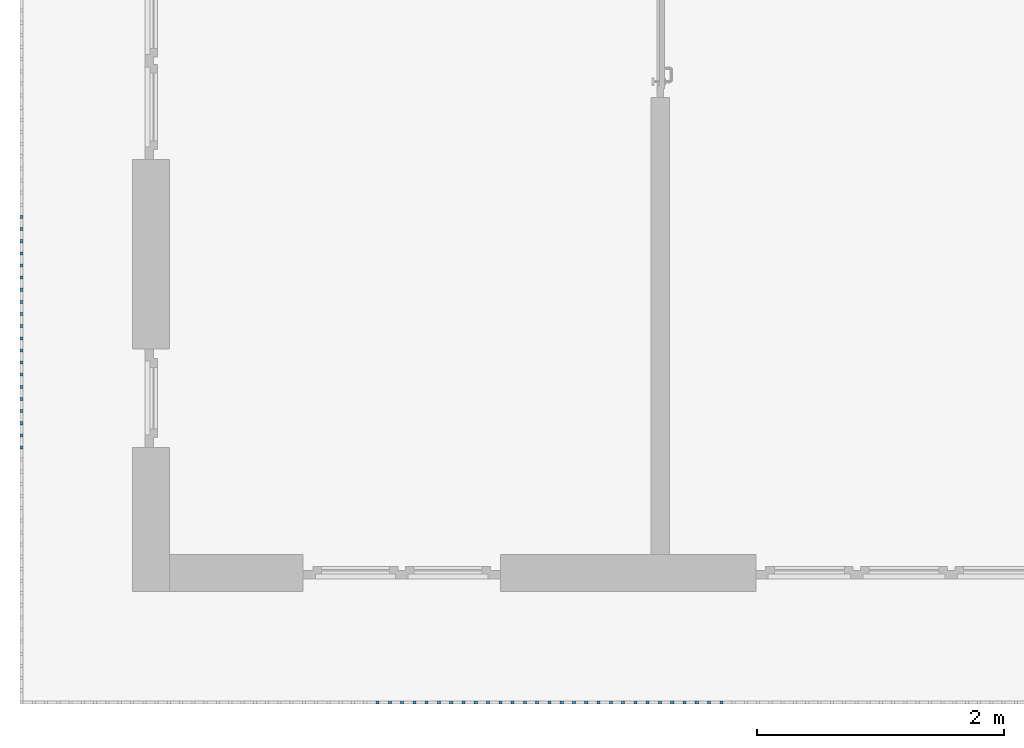
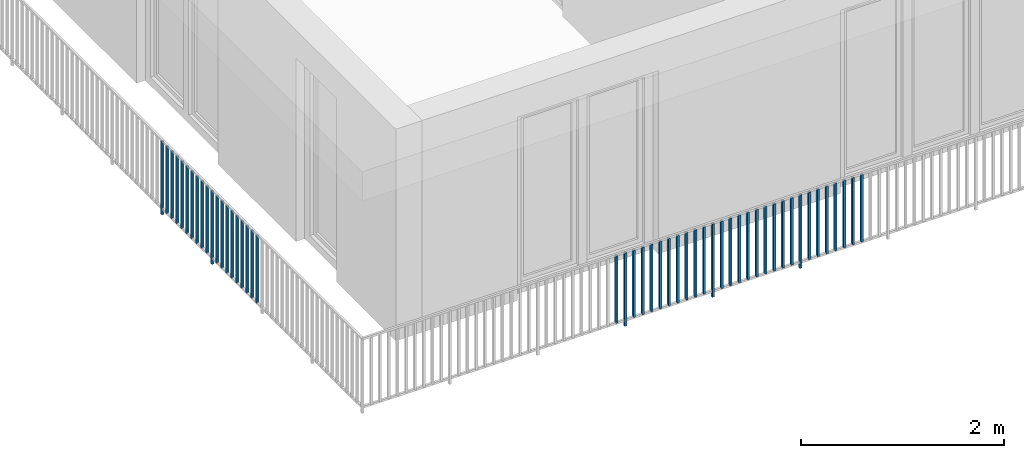
# One storey, part 32 of 54: 49 building element parts, 1 element without a shape of its own.
"""IFC4 building model written with IfcOpenShell, lengths in metres."""

from ifc_helpers import new_model, entity, si_unit, converted_unit, derived_unit, direction, frame, origin_with_axes, place, context, subcontext, project, spatial, polygons, material, type_object, element, aggregate, save


model = new_model("IFC4")

# Units and contexts
model_context = context("Model", 3, precision=1e-05, world=origin_with_axes(), true_north=direction((0.0, 1.0)))
body_context = subcontext(model_context, "Body", "Model", "MODEL_VIEW")
ifc_project = project(units=[si_unit("LENGTHUNIT", "METRE"), si_unit("AREAUNIT", "SQUARE_METRE"), si_unit("VOLUMEUNIT", "CUBIC_METRE"), converted_unit("PLANEANGLEUNIT", "DEGREE", entity("IfcPlaneAngleMeasure", 0.0174532925199), si_unit("PLANEANGLEUNIT", "RADIAN"), dimensions=[0, 0, 0, 0, 0, 0, 0]), converted_unit("TIMEUNIT", "Year", entity("IfcTimeMeasure", 31556926.0), si_unit("TIMEUNIT", "SECOND"), dimensions=[0, 0, 1, 0, 0, 0, 0]), si_unit("MASSUNIT", "GRAM", prefix="KILO"), si_unit("THERMODYNAMICTEMPERATUREUNIT", "DEGREE_CELSIUS"), si_unit("LUMINOUSINTENSITYUNIT", "LUMEN"), si_unit("ENERGYUNIT", "JOULE", prefix="MEGA"), derived_unit("THERMALCONDUCTANCEUNIT", [(si_unit("POWERUNIT", "WATT"), 1), (si_unit("LENGTHUNIT", "METRE"), -1), (si_unit("THERMODYNAMICTEMPERATUREUNIT", "KELVIN"), -1)]), derived_unit("SPECIFICHEATCAPACITYUNIT", [(si_unit("ENERGYUNIT", "JOULE"), 1), (si_unit("MASSUNIT", "GRAM", prefix="KILO"), -1), (si_unit("THERMODYNAMICTEMPERATUREUNIT", "KELVIN"), -1)]), derived_unit("MASSDENSITYUNIT", [(si_unit("MASSUNIT", "GRAM", prefix="KILO"), 1), (si_unit("VOLUMEUNIT", "CUBIC_METRE"), -1)])], contexts=[model_context])

# Site, building, storey, space
site_placement = place(None, origin_with_axes())
site = spatial("IfcSite", under=ifc_project, at=site_placement, CompositionType="ELEMENT")
building_placement = place(site_placement, origin_with_axes())
building = spatial("IfcBuilding", under=site, at=building_placement, CompositionType="ELEMENT")
storey_placement = place(building_placement, frame((0.0, 0.0, 6.29), z_axis=(0.0, 0.0, 1.0), x_axis=(1.0, 0.0, 0.0)))
storey = spatial("IfcBuildingStorey", under=building, at=storey_placement, Name="2. Geschoss", CompositionType="ELEMENT", Elevation=6.29)
space_placement = place(storey_placement, frame((10.2378006196, 9.82118769833, 0.0), z_axis=(0.0, 0.0, 1.0), x_axis=(-1.0, 0.0, 0.0)))
space = spatial("IfcSpace", under=storey, at=space_placement, CompositionType="ELEMENT", PredefinedType="EXTERNAL")

# Railing, building element parts
railing_type = type_object("IfcRailingType", PredefinedType="NOTDEFINED")
railing_placement = place(space_placement, frame((0.0, -7.06315681498e-08, 0.0), z_axis=(0.0, 0.0, 1.0), x_axis=(-1.0, 0.0, 0.0)))
railing = element("IfcRailing", 1, at=railing_placement, inside=space, type_object=railing_type, PredefinedType="NOTDEFINED")
ifc_material = material()
building_element_part_1_placement = place(railing_placement, origin_with_axes())
building_element_part_1 = element("IfcBuildingElementPart", 2, at=building_element_part_1_placement, material=ifc_material, PredefinedType="NOTDEFINED", context=body_context, shape_type="Tessellation", body=[
    polygons([(-22.8925, -16.7291666667, 0.0), (-22.8675, -16.7291666667, 0.0), (-22.8675, -16.7291666667, 0.88), (-22.8925, -16.7291666667, 0.88), (-22.8925, -16.7041666667, 0.0), (-22.8675, -16.7041666667, 0.0), (-22.8675, -16.7041666667, 0.88), (-22.8925, -16.7041666667, 0.88)], [[[1, 2, 3, 4]], [[1, 5, 6, 2]], [[2, 6, 7, 3]], [[4, 3, 7, 8]], [[5, 1, 4, 8]], [[6, 5, 8, 7]]], closed=True),
])
building_element_part_2_placement = place(railing_placement, origin_with_axes())
building_element_part_2 = element("IfcBuildingElementPart", 3, at=building_element_part_2_placement, material=ifc_material, PredefinedType="NOTDEFINED", context=body_context, shape_type="Tessellation", body=[
    polygons([(-22.8925, -16.8275, 0.07), (-22.8675, -16.8275, 0.07), (-22.8675, -16.8275, 0.8775), (-22.8925, -16.8275, 0.8775), (-22.8925, -16.8025, 0.07), (-22.8675, -16.8025, 0.07), (-22.8675, -16.8025, 0.8775), (-22.8925, -16.8025, 0.8775)], [[[1, 2, 3, 4]], [[1, 5, 6, 2]], [[2, 6, 7, 3]], [[4, 3, 7, 8]], [[5, 1, 4, 8]], [[6, 5, 8, 7]]], closed=True),
])
building_element_part_3_placement = place(railing_placement, origin_with_axes())
building_element_part_3 = element("IfcBuildingElementPart", 4, at=building_element_part_3_placement, material=ifc_material, PredefinedType="NOTDEFINED", context=body_context, shape_type="Tessellation", body=[
    polygons([(-22.8925, -16.9258333333, 0.07), (-22.8675, -16.9258333333, 0.07), (-22.8675, -16.9258333333, 0.8775), (-22.8925, -16.9258333333, 0.8775), (-22.8925, -16.9008333333, 0.07), (-22.8675, -16.9008333333, 0.07), (-22.8675, -16.9008333333, 0.8775), (-22.8925, -16.9008333333, 0.8775)], [[[1, 2, 3, 4]], [[1, 5, 6, 2]], [[2, 6, 7, 3]], [[4, 3, 7, 8]], [[5, 1, 4, 8]], [[6, 5, 8, 7]]], closed=True),
])
building_element_part_4_placement = place(railing_placement, origin_with_axes())
building_element_part_4 = element("IfcBuildingElementPart", 5, at=building_element_part_4_placement, material=ifc_material, PredefinedType="NOTDEFINED", context=body_context, shape_type="Tessellation", body=[
    polygons([(-22.8925, -17.0241666667, 0.07), (-22.8675, -17.0241666667, 0.07), (-22.8675, -17.0241666667, 0.8775), (-22.8925, -17.0241666667, 0.8775), (-22.8925, -16.9991666667, 0.07), (-22.8675, -16.9991666667, 0.07), (-22.8675, -16.9991666667, 0.8775), (-22.8925, -16.9991666667, 0.8775)], [[[1, 2, 3, 4]], [[1, 5, 6, 2]], [[2, 6, 7, 3]], [[4, 3, 7, 8]], [[5, 1, 4, 8]], [[6, 5, 8, 7]]], closed=True),
])
building_element_part_5_placement = place(railing_placement, origin_with_axes())
building_element_part_5 = element("IfcBuildingElementPart", 6, at=building_element_part_5_placement, material=ifc_material, PredefinedType="NOTDEFINED", context=body_context, shape_type="Tessellation", body=[
    polygons([(-22.8925, -17.1225, 0.07), (-22.8675, -17.1225, 0.07), (-22.8675, -17.1225, 0.8775), (-22.8925, -17.1225, 0.8775), (-22.8925, -17.0975, 0.07), (-22.8675, -17.0975, 0.07), (-22.8675, -17.0975, 0.8775), (-22.8925, -17.0975, 0.8775)], [[[1, 2, 3, 4]], [[1, 5, 6, 2]], [[2, 6, 7, 3]], [[4, 3, 7, 8]], [[5, 1, 4, 8]], [[6, 5, 8, 7]]], closed=True),
])
building_element_part_6_placement = place(railing_placement, origin_with_axes())
building_element_part_6 = element("IfcBuildingElementPart", 7, at=building_element_part_6_placement, material=ifc_material, PredefinedType="NOTDEFINED", context=body_context, shape_type="Tessellation", body=[
    polygons([(-22.8925, -17.2208333333, 0.07), (-22.8675, -17.2208333333, 0.07), (-22.8675, -17.2208333333, 0.8775), (-22.8925, -17.2208333333, 0.8775), (-22.8925, -17.1958333333, 0.07), (-22.8675, -17.1958333333, 0.07), (-22.8675, -17.1958333333, 0.8775), (-22.8925, -17.1958333333, 0.8775)], [[[1, 2, 3, 4]], [[1, 5, 6, 2]], [[2, 6, 7, 3]], [[4, 3, 7, 8]], [[5, 1, 4, 8]], [[6, 5, 8, 7]]], closed=True),
])
building_element_part_7_placement = place(railing_placement, origin_with_axes())
building_element_part_7 = element("IfcBuildingElementPart", 8, at=building_element_part_7_placement, material=ifc_material, PredefinedType="NOTDEFINED", context=body_context, shape_type="Tessellation", body=[
    polygons([(-22.8925, -17.3191666667, 0.07), (-22.8675, -17.3191666667, 0.07), (-22.8675, -17.3191666667, 0.8775), (-22.8925, -17.3191666667, 0.8775), (-22.8925, -17.2941666667, 0.07), (-22.8675, -17.2941666667, 0.07), (-22.8675, -17.2941666667, 0.8775), (-22.8925, -17.2941666667, 0.8775)], [[[1, 2, 3, 4]], [[1, 5, 6, 2]], [[2, 6, 7, 3]], [[4, 3, 7, 8]], [[5, 1, 4, 8]], [[6, 5, 8, 7]]], closed=True),
])
building_element_part_8_placement = place(railing_placement, origin_with_axes())
building_element_part_8 = element("IfcBuildingElementPart", 9, at=building_element_part_8_placement, material=ifc_material, PredefinedType="NOTDEFINED", context=body_context, shape_type="Tessellation", body=[
    polygons([(-22.8925, -17.4175, 0.07), (-22.8675, -17.4175, 0.07), (-22.8675, -17.4175, 0.8775), (-22.8925, -17.4175, 0.8775), (-22.8925, -17.3925, 0.07), (-22.8675, -17.3925, 0.07), (-22.8675, -17.3925, 0.8775), (-22.8925, -17.3925, 0.8775)], [[[1, 2, 3, 4]], [[1, 5, 6, 2]], [[2, 6, 7, 3]], [[4, 3, 7, 8]], [[5, 1, 4, 8]], [[6, 5, 8, 7]]], closed=True),
])
building_element_part_9_placement = place(railing_placement, origin_with_axes())
building_element_part_9 = element("IfcBuildingElementPart", 10, at=building_element_part_9_placement, material=ifc_material, PredefinedType="NOTDEFINED", context=body_context, shape_type="Tessellation", body=[
    polygons([(-22.8925, -17.5158333333, 0.07), (-22.8675, -17.5158333333, 0.07), (-22.8675, -17.5158333333, 0.8775), (-22.8925, -17.5158333333, 0.8775), (-22.8925, -17.4908333333, 0.07), (-22.8675, -17.4908333333, 0.07), (-22.8675, -17.4908333333, 0.8775), (-22.8925, -17.4908333333, 0.8775)], [[[1, 2, 3, 4]], [[1, 5, 6, 2]], [[2, 6, 7, 3]], [[4, 3, 7, 8]], [[5, 1, 4, 8]], [[6, 5, 8, 7]]], closed=True),
])
building_element_part_10_placement = place(railing_placement, origin_with_axes())
building_element_part_10 = element("IfcBuildingElementPart", 11, at=building_element_part_10_placement, material=ifc_material, PredefinedType="NOTDEFINED", context=body_context, shape_type="Tessellation", body=[
    polygons([(-22.8925, -17.6141666667, 0.07), (-22.8675, -17.6141666667, 0.07), (-22.8675, -17.6141666667, 0.8775), (-22.8925, -17.6141666667, 0.8775), (-22.8925, -17.5891666667, 0.07), (-22.8675, -17.5891666667, 0.07), (-22.8675, -17.5891666667, 0.8775), (-22.8925, -17.5891666667, 0.8775)], [[[1, 2, 3, 4]], [[1, 5, 6, 2]], [[2, 6, 7, 3]], [[4, 3, 7, 8]], [[5, 1, 4, 8]], [[6, 5, 8, 7]]], closed=True),
])
building_element_part_11_placement = place(railing_placement, origin_with_axes())
building_element_part_11 = element("IfcBuildingElementPart", 12, at=building_element_part_11_placement, material=ifc_material, PredefinedType="NOTDEFINED", context=body_context, shape_type="Tessellation", body=[
    polygons([(-22.8925, -17.7125, 0.0), (-22.8675, -17.7125, 0.0), (-22.8675, -17.7125, 0.88), (-22.8925, -17.7125, 0.88), (-22.8925, -17.6875, 0.0), (-22.8675, -17.6875, 0.0), (-22.8675, -17.6875, 0.88), (-22.8925, -17.6875, 0.88)], [[[1, 2, 3, 4]], [[1, 5, 6, 2]], [[2, 6, 7, 3]], [[4, 3, 7, 8]], [[5, 1, 4, 8]], [[6, 5, 8, 7]]], closed=True),
])
building_element_part_12_placement = place(railing_placement, origin_with_axes())
building_element_part_12 = element("IfcBuildingElementPart", 13, at=building_element_part_12_placement, material=ifc_material, PredefinedType="NOTDEFINED", context=body_context, shape_type="Tessellation", body=[
    polygons([(-22.8925, -17.8108333333, 0.07), (-22.8675, -17.8108333333, 0.07), (-22.8675, -17.8108333333, 0.8775), (-22.8925, -17.8108333333, 0.8775), (-22.8925, -17.7858333333, 0.07), (-22.8675, -17.7858333333, 0.07), (-22.8675, -17.7858333333, 0.8775), (-22.8925, -17.7858333333, 0.8775)], [[[1, 2, 3, 4]], [[1, 5, 6, 2]], [[2, 6, 7, 3]], [[4, 3, 7, 8]], [[5, 1, 4, 8]], [[6, 5, 8, 7]]], closed=True),
])
building_element_part_13_placement = place(railing_placement, origin_with_axes())
building_element_part_13 = element("IfcBuildingElementPart", 14, at=building_element_part_13_placement, material=ifc_material, PredefinedType="NOTDEFINED", context=body_context, shape_type="Tessellation", body=[
    polygons([(-22.8925, -17.9091666667, 0.07), (-22.8675, -17.9091666667, 0.07), (-22.8675, -17.9091666667, 0.8775), (-22.8925, -17.9091666667, 0.8775), (-22.8925, -17.8841666667, 0.07), (-22.8675, -17.8841666667, 0.07), (-22.8675, -17.8841666667, 0.8775), (-22.8925, -17.8841666667, 0.8775)], [[[1, 2, 3, 4]], [[1, 5, 6, 2]], [[2, 6, 7, 3]], [[4, 3, 7, 8]], [[5, 1, 4, 8]], [[6, 5, 8, 7]]], closed=True),
])
building_element_part_14_placement = place(railing_placement, origin_with_axes())
building_element_part_14 = element("IfcBuildingElementPart", 15, at=building_element_part_14_placement, material=ifc_material, PredefinedType="NOTDEFINED", context=body_context, shape_type="Tessellation", body=[
    polygons([(-22.8925, -18.0075, 0.07), (-22.8675, -18.0075, 0.07), (-22.8675, -18.0075, 0.8775), (-22.8925, -18.0075, 0.8775), (-22.8925, -17.9825, 0.07), (-22.8675, -17.9825, 0.07), (-22.8675, -17.9825, 0.8775), (-22.8925, -17.9825, 0.8775)], [[[1, 2, 3, 4]], [[1, 5, 6, 2]], [[2, 6, 7, 3]], [[4, 3, 7, 8]], [[5, 1, 4, 8]], [[6, 5, 8, 7]]], closed=True),
])
building_element_part_15_placement = place(railing_placement, origin_with_axes())
building_element_part_15 = element("IfcBuildingElementPart", 16, at=building_element_part_15_placement, material=ifc_material, PredefinedType="NOTDEFINED", context=body_context, shape_type="Tessellation", body=[
    polygons([(-22.8925, -18.1058333333, 0.07), (-22.8675, -18.1058333333, 0.07), (-22.8675, -18.1058333333, 0.8775), (-22.8925, -18.1058333333, 0.8775), (-22.8925, -18.0808333333, 0.07), (-22.8675, -18.0808333333, 0.07), (-22.8675, -18.0808333333, 0.8775), (-22.8925, -18.0808333333, 0.8775)], [[[1, 2, 3, 4]], [[1, 5, 6, 2]], [[2, 6, 7, 3]], [[4, 3, 7, 8]], [[5, 1, 4, 8]], [[6, 5, 8, 7]]], closed=True),
])
building_element_part_16_placement = place(railing_placement, origin_with_axes())
building_element_part_16 = element("IfcBuildingElementPart", 17, at=building_element_part_16_placement, material=ifc_material, PredefinedType="NOTDEFINED", context=body_context, shape_type="Tessellation", body=[
    polygons([(-22.8925, -18.2041666667, 0.07), (-22.8675, -18.2041666667, 0.07), (-22.8675, -18.2041666667, 0.8775), (-22.8925, -18.2041666667, 0.8775), (-22.8925, -18.1791666667, 0.07), (-22.8675, -18.1791666667, 0.07), (-22.8675, -18.1791666667, 0.8775), (-22.8925, -18.1791666667, 0.8775)], [[[1, 2, 3, 4]], [[1, 5, 6, 2]], [[2, 6, 7, 3]], [[4, 3, 7, 8]], [[5, 1, 4, 8]], [[6, 5, 8, 7]]], closed=True),
])
building_element_part_17_placement = place(railing_placement, origin_with_axes())
building_element_part_17 = element("IfcBuildingElementPart", 18, at=building_element_part_17_placement, material=ifc_material, PredefinedType="NOTDEFINED", context=body_context, shape_type="Tessellation", body=[
    polygons([(-22.8925, -18.3025, 0.07), (-22.8675, -18.3025, 0.07), (-22.8675, -18.3025, 0.8775), (-22.8925, -18.3025, 0.8775), (-22.8925, -18.2775, 0.07), (-22.8675, -18.2775, 0.07), (-22.8675, -18.2775, 0.8775), (-22.8925, -18.2775, 0.8775)], [[[1, 2, 3, 4]], [[1, 5, 6, 2]], [[2, 6, 7, 3]], [[4, 3, 7, 8]], [[5, 1, 4, 8]], [[6, 5, 8, 7]]], closed=True),
])
building_element_part_18_placement = place(railing_placement, origin_with_axes())
building_element_part_18 = element("IfcBuildingElementPart", 19, at=building_element_part_18_placement, material=ifc_material, PredefinedType="NOTDEFINED", context=body_context, shape_type="Tessellation", body=[
    polygons([(-22.8925, -18.4008333333, 0.07), (-22.8675, -18.4008333333, 0.07), (-22.8675, -18.4008333333, 0.8775), (-22.8925, -18.4008333333, 0.8775), (-22.8925, -18.3758333333, 0.07), (-22.8675, -18.3758333333, 0.07), (-22.8675, -18.3758333333, 0.8775), (-22.8925, -18.3758333333, 0.8775)], [[[1, 2, 3, 4]], [[1, 5, 6, 2]], [[2, 6, 7, 3]], [[4, 3, 7, 8]], [[5, 1, 4, 8]], [[6, 5, 8, 7]]], closed=True),
])
building_element_part_19_placement = place(railing_placement, origin_with_axes())
building_element_part_19 = element("IfcBuildingElementPart", 20, at=building_element_part_19_placement, material=ifc_material, PredefinedType="NOTDEFINED", context=body_context, shape_type="Tessellation", body=[
    polygons([(-22.8925, -18.4991666667, 0.07), (-22.8675, -18.4991666667, 0.07), (-22.8675, -18.4991666667, 0.8775), (-22.8925, -18.4991666667, 0.8775), (-22.8925, -18.4741666667, 0.07), (-22.8675, -18.4741666667, 0.07), (-22.8675, -18.4741666667, 0.8775), (-22.8925, -18.4741666667, 0.8775)], [[[1, 2, 3, 4]], [[1, 5, 6, 2]], [[2, 6, 7, 3]], [[4, 3, 7, 8]], [[5, 1, 4, 8]], [[6, 5, 8, 7]]], closed=True),
])
building_element_part_20_placement = place(railing_placement, origin_with_axes())
building_element_part_20 = element("IfcBuildingElementPart", 21, at=building_element_part_20_placement, material=ifc_material, PredefinedType="NOTDEFINED", context=body_context, shape_type="Tessellation", body=[
    polygons([(-22.8925, -18.5975, 0.07), (-22.8675, -18.5975, 0.07), (-22.8675, -18.5975, 0.8775), (-22.8925, -18.5975, 0.8775), (-22.8925, -18.5725, 0.07), (-22.8675, -18.5725, 0.07), (-22.8675, -18.5725, 0.8775), (-22.8925, -18.5725, 0.8775)], [[[1, 2, 3, 4]], [[1, 5, 6, 2]], [[2, 6, 7, 3]], [[4, 3, 7, 8]], [[5, 1, 4, 8]], [[6, 5, 8, 7]]], closed=True),
])
building_element_part_21_placement = place(railing_placement, origin_with_axes())
building_element_part_21 = element("IfcBuildingElementPart", 22, at=building_element_part_21_placement, material=ifc_material, PredefinedType="NOTDEFINED", context=body_context, shape_type="Tessellation", body=[
    polygons([(-19.9826304348, -20.6625, 0.07), (-19.9826304348, -20.6375, 0.07), (-19.9826304348, -20.6375, 0.8775), (-19.9826304348, -20.6625, 0.8775), (-20.0076304348, -20.6625, 0.07), (-20.0076304348, -20.6375, 0.07), (-20.0076304348, -20.6375, 0.8775), (-20.0076304348, -20.6625, 0.8775)], [[[1, 2, 3, 4]], [[1, 5, 6, 2]], [[2, 6, 7, 3]], [[4, 3, 7, 8]], [[5, 1, 4, 8]], [[6, 5, 8, 7]]], closed=True),
])
building_element_part_22_placement = place(railing_placement, origin_with_axes())
building_element_part_22 = element("IfcBuildingElementPart", 23, at=building_element_part_22_placement, material=ifc_material, PredefinedType="NOTDEFINED", context=body_context, shape_type="Tessellation", body=[
    polygons([(-19.8831521739, -20.6625, 0.0), (-19.8831521739, -20.6375, 0.0), (-19.8831521739, -20.6375, 0.88), (-19.8831521739, -20.6625, 0.88), (-19.9081521739, -20.6625, 0.0), (-19.9081521739, -20.6375, 0.0), (-19.9081521739, -20.6375, 0.88), (-19.9081521739, -20.6625, 0.88)], [[[1, 2, 3, 4]], [[1, 5, 6, 2]], [[2, 6, 7, 3]], [[4, 3, 7, 8]], [[5, 1, 4, 8]], [[6, 5, 8, 7]]], closed=True),
])
building_element_part_23_placement = place(railing_placement, origin_with_axes())
building_element_part_23 = element("IfcBuildingElementPart", 24, at=building_element_part_23_placement, material=ifc_material, PredefinedType="NOTDEFINED", context=body_context, shape_type="Tessellation", body=[
    polygons([(-19.783673913, -20.6625, 0.07), (-19.783673913, -20.6375, 0.07), (-19.783673913, -20.6375, 0.8775), (-19.783673913, -20.6625, 0.8775), (-19.808673913, -20.6625, 0.07), (-19.808673913, -20.6375, 0.07), (-19.808673913, -20.6375, 0.8775), (-19.808673913, -20.6625, 0.8775)], [[[1, 2, 3, 4]], [[1, 5, 6, 2]], [[2, 6, 7, 3]], [[4, 3, 7, 8]], [[5, 1, 4, 8]], [[6, 5, 8, 7]]], closed=True),
])
building_element_part_24_placement = place(railing_placement, origin_with_axes())
building_element_part_24 = element("IfcBuildingElementPart", 25, at=building_element_part_24_placement, material=ifc_material, PredefinedType="NOTDEFINED", context=body_context, shape_type="Tessellation", body=[
    polygons([(-19.6841956522, -20.6625, 0.07), (-19.6841956522, -20.6375, 0.07), (-19.6841956522, -20.6375, 0.8775), (-19.6841956522, -20.6625, 0.8775), (-19.7091956522, -20.6625, 0.07), (-19.7091956522, -20.6375, 0.07), (-19.7091956522, -20.6375, 0.8775), (-19.7091956522, -20.6625, 0.8775)], [[[1, 2, 3, 4]], [[1, 5, 6, 2]], [[2, 6, 7, 3]], [[4, 3, 7, 8]], [[5, 1, 4, 8]], [[6, 5, 8, 7]]], closed=True),
])
building_element_part_25_placement = place(railing_placement, origin_with_axes())
building_element_part_25 = element("IfcBuildingElementPart", 26, at=building_element_part_25_placement, material=ifc_material, PredefinedType="NOTDEFINED", context=body_context, shape_type="Tessellation", body=[
    polygons([(-19.5847173913, -20.6625, 0.07), (-19.5847173913, -20.6375, 0.07), (-19.5847173913, -20.6375, 0.8775), (-19.5847173913, -20.6625, 0.8775), (-19.6097173913, -20.6625, 0.07), (-19.6097173913, -20.6375, 0.07), (-19.6097173913, -20.6375, 0.8775), (-19.6097173913, -20.6625, 0.8775)], [[[1, 2, 3, 4]], [[1, 5, 6, 2]], [[2, 6, 7, 3]], [[4, 3, 7, 8]], [[5, 1, 4, 8]], [[6, 5, 8, 7]]], closed=True),
])
building_element_part_26_placement = place(railing_placement, origin_with_axes())
building_element_part_26 = element("IfcBuildingElementPart", 27, at=building_element_part_26_placement, material=ifc_material, PredefinedType="NOTDEFINED", context=body_context, shape_type="Tessellation", body=[
    polygons([(-19.4852391304, -20.6625, 0.07), (-19.4852391304, -20.6375, 0.07), (-19.4852391304, -20.6375, 0.8775), (-19.4852391304, -20.6625, 0.8775), (-19.5102391304, -20.6625, 0.07), (-19.5102391304, -20.6375, 0.07), (-19.5102391304, -20.6375, 0.8775), (-19.5102391304, -20.6625, 0.8775)], [[[1, 2, 3, 4]], [[1, 5, 6, 2]], [[2, 6, 7, 3]], [[4, 3, 7, 8]], [[5, 1, 4, 8]], [[6, 5, 8, 7]]], closed=True),
])
building_element_part_27_placement = place(railing_placement, origin_with_axes())
building_element_part_27 = element("IfcBuildingElementPart", 28, at=building_element_part_27_placement, material=ifc_material, PredefinedType="NOTDEFINED", context=body_context, shape_type="Tessellation", body=[
    polygons([(-19.3857608696, -20.6625, 0.07), (-19.3857608696, -20.6375, 0.07), (-19.3857608696, -20.6375, 0.8775), (-19.3857608696, -20.6625, 0.8775), (-19.4107608696, -20.6625, 0.07), (-19.4107608696, -20.6375, 0.07), (-19.4107608696, -20.6375, 0.8775), (-19.4107608696, -20.6625, 0.8775)], [[[1, 2, 3, 4]], [[1, 5, 6, 2]], [[2, 6, 7, 3]], [[4, 3, 7, 8]], [[5, 1, 4, 8]], [[6, 5, 8, 7]]], closed=True),
])
building_element_part_28_placement = place(railing_placement, origin_with_axes())
building_element_part_28 = element("IfcBuildingElementPart", 29, at=building_element_part_28_placement, material=ifc_material, PredefinedType="NOTDEFINED", context=body_context, shape_type="Tessellation", body=[
    polygons([(-19.2862826087, -20.6625, 0.07), (-19.2862826087, -20.6375, 0.07), (-19.2862826087, -20.6375, 0.8775), (-19.2862826087, -20.6625, 0.8775), (-19.3112826087, -20.6625, 0.07), (-19.3112826087, -20.6375, 0.07), (-19.3112826087, -20.6375, 0.8775), (-19.3112826087, -20.6625, 0.8775)], [[[1, 2, 3, 4]], [[1, 5, 6, 2]], [[2, 6, 7, 3]], [[4, 3, 7, 8]], [[5, 1, 4, 8]], [[6, 5, 8, 7]]], closed=True),
])
building_element_part_29_placement = place(railing_placement, origin_with_axes())
building_element_part_29 = element("IfcBuildingElementPart", 30, at=building_element_part_29_placement, material=ifc_material, PredefinedType="NOTDEFINED", context=body_context, shape_type="Tessellation", body=[
    polygons([(-19.1868043478, -20.6625, 0.07), (-19.1868043478, -20.6375, 0.07), (-19.1868043478, -20.6375, 0.8775), (-19.1868043478, -20.6625, 0.8775), (-19.2118043478, -20.6625, 0.07), (-19.2118043478, -20.6375, 0.07), (-19.2118043478, -20.6375, 0.8775), (-19.2118043478, -20.6625, 0.8775)], [[[1, 2, 3, 4]], [[1, 5, 6, 2]], [[2, 6, 7, 3]], [[4, 3, 7, 8]], [[5, 1, 4, 8]], [[6, 5, 8, 7]]], closed=True),
])
building_element_part_30_placement = place(railing_placement, origin_with_axes())
building_element_part_30 = element("IfcBuildingElementPart", 31, at=building_element_part_30_placement, material=ifc_material, PredefinedType="NOTDEFINED", context=body_context, shape_type="Tessellation", body=[
    polygons([(-19.087326087, -20.6625, 0.07), (-19.087326087, -20.6375, 0.07), (-19.087326087, -20.6375, 0.8775), (-19.087326087, -20.6625, 0.8775), (-19.112326087, -20.6625, 0.07), (-19.112326087, -20.6375, 0.07), (-19.112326087, -20.6375, 0.8775), (-19.112326087, -20.6625, 0.8775)], [[[1, 2, 3, 4]], [[1, 5, 6, 2]], [[2, 6, 7, 3]], [[4, 3, 7, 8]], [[5, 1, 4, 8]], [[6, 5, 8, 7]]], closed=True),
])
building_element_part_31_placement = place(railing_placement, origin_with_axes())
building_element_part_31 = element("IfcBuildingElementPart", 32, at=building_element_part_31_placement, material=ifc_material, PredefinedType="NOTDEFINED", context=body_context, shape_type="Tessellation", body=[
    polygons([(-18.9878478261, -20.6625, 0.07), (-18.9878478261, -20.6375, 0.07), (-18.9878478261, -20.6375, 0.8775), (-18.9878478261, -20.6625, 0.8775), (-19.0128478261, -20.6625, 0.07), (-19.0128478261, -20.6375, 0.07), (-19.0128478261, -20.6375, 0.8775), (-19.0128478261, -20.6625, 0.8775)], [[[1, 2, 3, 4]], [[1, 5, 6, 2]], [[2, 6, 7, 3]], [[4, 3, 7, 8]], [[5, 1, 4, 8]], [[6, 5, 8, 7]]], closed=True),
])
building_element_part_32_placement = place(railing_placement, origin_with_axes())
building_element_part_32 = element("IfcBuildingElementPart", 33, at=building_element_part_32_placement, material=ifc_material, PredefinedType="NOTDEFINED", context=body_context, shape_type="Tessellation", body=[
    polygons([(-18.8883695652, -20.6625, 0.0), (-18.8883695652, -20.6375, 0.0), (-18.8883695652, -20.6375, 0.88), (-18.8883695652, -20.6625, 0.88), (-18.9133695652, -20.6625, 0.0), (-18.9133695652, -20.6375, 0.0), (-18.9133695652, -20.6375, 0.88), (-18.9133695652, -20.6625, 0.88)], [[[1, 2, 3, 4]], [[1, 5, 6, 2]], [[2, 6, 7, 3]], [[4, 3, 7, 8]], [[5, 1, 4, 8]], [[6, 5, 8, 7]]], closed=True),
])
building_element_part_33_placement = place(railing_placement, origin_with_axes())
building_element_part_33 = element("IfcBuildingElementPart", 34, at=building_element_part_33_placement, material=ifc_material, PredefinedType="NOTDEFINED", context=body_context, shape_type="Tessellation", body=[
    polygons([(-18.7888913043, -20.6625, 0.07), (-18.7888913043, -20.6375, 0.07), (-18.7888913043, -20.6375, 0.8775), (-18.7888913043, -20.6625, 0.8775), (-18.8138913043, -20.6625, 0.07), (-18.8138913043, -20.6375, 0.07), (-18.8138913043, -20.6375, 0.8775), (-18.8138913043, -20.6625, 0.8775)], [[[1, 2, 3, 4]], [[1, 5, 6, 2]], [[2, 6, 7, 3]], [[4, 3, 7, 8]], [[5, 1, 4, 8]], [[6, 5, 8, 7]]], closed=True),
])
building_element_part_34_placement = place(railing_placement, origin_with_axes())
building_element_part_34 = element("IfcBuildingElementPart", 35, at=building_element_part_34_placement, material=ifc_material, PredefinedType="NOTDEFINED", context=body_context, shape_type="Tessellation", body=[
    polygons([(-18.6894130435, -20.6625, 0.07), (-18.6894130435, -20.6375, 0.07), (-18.6894130435, -20.6375, 0.8775), (-18.6894130435, -20.6625, 0.8775), (-18.7144130435, -20.6625, 0.07), (-18.7144130435, -20.6375, 0.07), (-18.7144130435, -20.6375, 0.8775), (-18.7144130435, -20.6625, 0.8775)], [[[1, 2, 3, 4]], [[1, 5, 6, 2]], [[2, 6, 7, 3]], [[4, 3, 7, 8]], [[5, 1, 4, 8]], [[6, 5, 8, 7]]], closed=True),
])
building_element_part_35_placement = place(railing_placement, origin_with_axes())
building_element_part_35 = element("IfcBuildingElementPart", 36, at=building_element_part_35_placement, material=ifc_material, PredefinedType="NOTDEFINED", context=body_context, shape_type="Tessellation", body=[
    polygons([(-18.5899347826, -20.6625, 0.07), (-18.5899347826, -20.6375, 0.07), (-18.5899347826, -20.6375, 0.8775), (-18.5899347826, -20.6625, 0.8775), (-18.6149347826, -20.6625, 0.07), (-18.6149347826, -20.6375, 0.07), (-18.6149347826, -20.6375, 0.8775), (-18.6149347826, -20.6625, 0.8775)], [[[1, 2, 3, 4]], [[1, 5, 6, 2]], [[2, 6, 7, 3]], [[4, 3, 7, 8]], [[5, 1, 4, 8]], [[6, 5, 8, 7]]], closed=True),
])
building_element_part_36_placement = place(railing_placement, origin_with_axes())
building_element_part_36 = element("IfcBuildingElementPart", 37, at=building_element_part_36_placement, material=ifc_material, PredefinedType="NOTDEFINED", context=body_context, shape_type="Tessellation", body=[
    polygons([(-18.4904565217, -20.6625, 0.07), (-18.4904565217, -20.6375, 0.07), (-18.4904565217, -20.6375, 0.8775), (-18.4904565217, -20.6625, 0.8775), (-18.5154565217, -20.6625, 0.07), (-18.5154565217, -20.6375, 0.07), (-18.5154565217, -20.6375, 0.8775), (-18.5154565217, -20.6625, 0.8775)], [[[1, 2, 3, 4]], [[1, 5, 6, 2]], [[2, 6, 7, 3]], [[4, 3, 7, 8]], [[5, 1, 4, 8]], [[6, 5, 8, 7]]], closed=True),
])
building_element_part_37_placement = place(railing_placement, origin_with_axes())
building_element_part_37 = element("IfcBuildingElementPart", 38, at=building_element_part_37_placement, material=ifc_material, PredefinedType="NOTDEFINED", context=body_context, shape_type="Tessellation", body=[
    polygons([(-18.3909782609, -20.6625, 0.07), (-18.3909782609, -20.6375, 0.07), (-18.3909782609, -20.6375, 0.8775), (-18.3909782609, -20.6625, 0.8775), (-18.4159782609, -20.6625, 0.07), (-18.4159782609, -20.6375, 0.07), (-18.4159782609, -20.6375, 0.8775), (-18.4159782609, -20.6625, 0.8775)], [[[1, 2, 3, 4]], [[1, 5, 6, 2]], [[2, 6, 7, 3]], [[4, 3, 7, 8]], [[5, 1, 4, 8]], [[6, 5, 8, 7]]], closed=True),
])
building_element_part_38_placement = place(railing_placement, origin_with_axes())
building_element_part_38 = element("IfcBuildingElementPart", 39, at=building_element_part_38_placement, material=ifc_material, PredefinedType="NOTDEFINED", context=body_context, shape_type="Tessellation", body=[
    polygons([(-18.2915, -20.6625, 0.07), (-18.2915, -20.6375, 0.07), (-18.2915, -20.6375, 0.8775), (-18.2915, -20.6625, 0.8775), (-18.3165, -20.6625, 0.07), (-18.3165, -20.6375, 0.07), (-18.3165, -20.6375, 0.8775), (-18.3165, -20.6625, 0.8775)], [[[1, 2, 3, 4]], [[1, 5, 6, 2]], [[2, 6, 7, 3]], [[4, 3, 7, 8]], [[5, 1, 4, 8]], [[6, 5, 8, 7]]], closed=True),
])
building_element_part_39_placement = place(railing_placement, origin_with_axes())
building_element_part_39 = element("IfcBuildingElementPart", 40, at=building_element_part_39_placement, material=ifc_material, PredefinedType="NOTDEFINED", context=body_context, shape_type="Tessellation", body=[
    polygons([(-18.1920217391, -20.6625, 0.07), (-18.1920217391, -20.6375, 0.07), (-18.1920217391, -20.6375, 0.8775), (-18.1920217391, -20.6625, 0.8775), (-18.2170217391, -20.6625, 0.07), (-18.2170217391, -20.6375, 0.07), (-18.2170217391, -20.6375, 0.8775), (-18.2170217391, -20.6625, 0.8775)], [[[1, 2, 3, 4]], [[1, 5, 6, 2]], [[2, 6, 7, 3]], [[4, 3, 7, 8]], [[5, 1, 4, 8]], [[6, 5, 8, 7]]], closed=True),
])
building_element_part_40_placement = place(railing_placement, origin_with_axes())
building_element_part_40 = element("IfcBuildingElementPart", 41, at=building_element_part_40_placement, material=ifc_material, PredefinedType="NOTDEFINED", context=body_context, shape_type="Tessellation", body=[
    polygons([(-18.0925434783, -20.6625, 0.07), (-18.0925434783, -20.6375, 0.07), (-18.0925434783, -20.6375, 0.8775), (-18.0925434783, -20.6625, 0.8775), (-18.1175434783, -20.6625, 0.07), (-18.1175434783, -20.6375, 0.07), (-18.1175434783, -20.6375, 0.8775), (-18.1175434783, -20.6625, 0.8775)], [[[1, 2, 3, 4]], [[1, 5, 6, 2]], [[2, 6, 7, 3]], [[4, 3, 7, 8]], [[5, 1, 4, 8]], [[6, 5, 8, 7]]], closed=True),
])
building_element_part_41_placement = place(railing_placement, origin_with_axes())
building_element_part_41 = element("IfcBuildingElementPart", 42, at=building_element_part_41_placement, material=ifc_material, PredefinedType="NOTDEFINED", context=body_context, shape_type="Tessellation", body=[
    polygons([(-17.9930652174, -20.6625, 0.07), (-17.9930652174, -20.6375, 0.07), (-17.9930652174, -20.6375, 0.8775), (-17.9930652174, -20.6625, 0.8775), (-18.0180652174, -20.6625, 0.07), (-18.0180652174, -20.6375, 0.07), (-18.0180652174, -20.6375, 0.8775), (-18.0180652174, -20.6625, 0.8775)], [[[1, 2, 3, 4]], [[1, 5, 6, 2]], [[2, 6, 7, 3]], [[4, 3, 7, 8]], [[5, 1, 4, 8]], [[6, 5, 8, 7]]], closed=True),
])
building_element_part_42_placement = place(railing_placement, origin_with_axes())
building_element_part_42 = element("IfcBuildingElementPart", 43, at=building_element_part_42_placement, material=ifc_material, PredefinedType="NOTDEFINED", context=body_context, shape_type="Tessellation", body=[
    polygons([(-17.8935869565, -20.6625, 0.0), (-17.8935869565, -20.6375, 0.0), (-17.8935869565, -20.6375, 0.88), (-17.8935869565, -20.6625, 0.88), (-17.9185869565, -20.6625, 0.0), (-17.9185869565, -20.6375, 0.0), (-17.9185869565, -20.6375, 0.88), (-17.9185869565, -20.6625, 0.88)], [[[1, 2, 3, 4]], [[1, 5, 6, 2]], [[2, 6, 7, 3]], [[4, 3, 7, 8]], [[5, 1, 4, 8]], [[6, 5, 8, 7]]], closed=True),
])
building_element_part_43_placement = place(railing_placement, origin_with_axes())
building_element_part_43 = element("IfcBuildingElementPart", 44, at=building_element_part_43_placement, material=ifc_material, PredefinedType="NOTDEFINED", context=body_context, shape_type="Tessellation", body=[
    polygons([(-17.7941086957, -20.6625, 0.07), (-17.7941086957, -20.6375, 0.07), (-17.7941086957, -20.6375, 0.8775), (-17.7941086957, -20.6625, 0.8775), (-17.8191086957, -20.6625, 0.07), (-17.8191086957, -20.6375, 0.07), (-17.8191086957, -20.6375, 0.8775), (-17.8191086957, -20.6625, 0.8775)], [[[1, 2, 3, 4]], [[1, 5, 6, 2]], [[2, 6, 7, 3]], [[4, 3, 7, 8]], [[5, 1, 4, 8]], [[6, 5, 8, 7]]], closed=True),
])
building_element_part_44_placement = place(railing_placement, origin_with_axes())
building_element_part_44 = element("IfcBuildingElementPart", 45, at=building_element_part_44_placement, material=ifc_material, PredefinedType="NOTDEFINED", context=body_context, shape_type="Tessellation", body=[
    polygons([(-17.6946304348, -20.6625, 0.07), (-17.6946304348, -20.6375, 0.07), (-17.6946304348, -20.6375, 0.8775), (-17.6946304348, -20.6625, 0.8775), (-17.7196304348, -20.6625, 0.07), (-17.7196304348, -20.6375, 0.07), (-17.7196304348, -20.6375, 0.8775), (-17.7196304348, -20.6625, 0.8775)], [[[1, 2, 3, 4]], [[1, 5, 6, 2]], [[2, 6, 7, 3]], [[4, 3, 7, 8]], [[5, 1, 4, 8]], [[6, 5, 8, 7]]], closed=True),
])
building_element_part_45_placement = place(railing_placement, origin_with_axes())
building_element_part_45 = element("IfcBuildingElementPart", 46, at=building_element_part_45_placement, material=ifc_material, PredefinedType="NOTDEFINED", context=body_context, shape_type="Tessellation", body=[
    polygons([(-17.5951521739, -20.6625, 0.07), (-17.5951521739, -20.6375, 0.07), (-17.5951521739, -20.6375, 0.8775), (-17.5951521739, -20.6625, 0.8775), (-17.6201521739, -20.6625, 0.07), (-17.6201521739, -20.6375, 0.07), (-17.6201521739, -20.6375, 0.8775), (-17.6201521739, -20.6625, 0.8775)], [[[1, 2, 3, 4]], [[1, 5, 6, 2]], [[2, 6, 7, 3]], [[4, 3, 7, 8]], [[5, 1, 4, 8]], [[6, 5, 8, 7]]], closed=True),
])
building_element_part_46_placement = place(railing_placement, origin_with_axes())
building_element_part_46 = element("IfcBuildingElementPart", 47, at=building_element_part_46_placement, material=ifc_material, PredefinedType="NOTDEFINED", context=body_context, shape_type="Tessellation", body=[
    polygons([(-17.495673913, -20.6625, 0.07), (-17.495673913, -20.6375, 0.07), (-17.495673913, -20.6375, 0.8775), (-17.495673913, -20.6625, 0.8775), (-17.520673913, -20.6625, 0.07), (-17.520673913, -20.6375, 0.07), (-17.520673913, -20.6375, 0.8775), (-17.520673913, -20.6625, 0.8775)], [[[1, 2, 3, 4]], [[1, 5, 6, 2]], [[2, 6, 7, 3]], [[4, 3, 7, 8]], [[5, 1, 4, 8]], [[6, 5, 8, 7]]], closed=True),
])
building_element_part_47_placement = place(railing_placement, origin_with_axes())
building_element_part_47 = element("IfcBuildingElementPart", 48, at=building_element_part_47_placement, material=ifc_material, PredefinedType="NOTDEFINED", context=body_context, shape_type="Tessellation", body=[
    polygons([(-17.3961956522, -20.6625, 0.07), (-17.3961956522, -20.6375, 0.07), (-17.3961956522, -20.6375, 0.8775), (-17.3961956522, -20.6625, 0.8775), (-17.4211956522, -20.6625, 0.07), (-17.4211956522, -20.6375, 0.07), (-17.4211956522, -20.6375, 0.8775), (-17.4211956522, -20.6625, 0.8775)], [[[1, 2, 3, 4]], [[1, 5, 6, 2]], [[2, 6, 7, 3]], [[4, 3, 7, 8]], [[5, 1, 4, 8]], [[6, 5, 8, 7]]], closed=True),
])
building_element_part_48_placement = place(railing_placement, origin_with_axes())
building_element_part_48 = element("IfcBuildingElementPart", 49, at=building_element_part_48_placement, material=ifc_material, PredefinedType="NOTDEFINED", context=body_context, shape_type="Tessellation", body=[
    polygons([(-17.2967173913, -20.6625, 0.07), (-17.2967173913, -20.6375, 0.07), (-17.2967173913, -20.6375, 0.8775), (-17.2967173913, -20.6625, 0.8775), (-17.3217173913, -20.6625, 0.07), (-17.3217173913, -20.6375, 0.07), (-17.3217173913, -20.6375, 0.8775), (-17.3217173913, -20.6625, 0.8775)], [[[1, 2, 3, 4]], [[1, 5, 6, 2]], [[2, 6, 7, 3]], [[4, 3, 7, 8]], [[5, 1, 4, 8]], [[6, 5, 8, 7]]], closed=True),
])
building_element_part_49_placement = place(railing_placement, origin_with_axes())
building_element_part_49 = element("IfcBuildingElementPart", 50, at=building_element_part_49_placement, material=ifc_material, PredefinedType="NOTDEFINED", context=body_context, shape_type="Tessellation", body=[
    polygons([(-17.1972391304, -20.6625, 0.07), (-17.1972391304, -20.6375, 0.07), (-17.1972391304, -20.6375, 0.8775), (-17.1972391304, -20.6625, 0.8775), (-17.2222391304, -20.6625, 0.07), (-17.2222391304, -20.6375, 0.07), (-17.2222391304, -20.6375, 0.8775), (-17.2222391304, -20.6625, 0.8775)], [[[1, 2, 3, 4]], [[1, 5, 6, 2]], [[2, 6, 7, 3]], [[4, 3, 7, 8]], [[5, 1, 4, 8]], [[6, 5, 8, 7]]], closed=True),
])
aggregate(railing, [building_element_part_1, building_element_part_2, building_element_part_3, building_element_part_4, building_element_part_5, building_element_part_6, building_element_part_7, building_element_part_8, building_element_part_9, building_element_part_10, building_element_part_11, building_element_part_12, building_element_part_13, building_element_part_14, building_element_part_15, building_element_part_16, building_element_part_17, building_element_part_18, building_element_part_19, building_element_part_20, building_element_part_21, building_element_part_22, building_element_part_23, building_element_part_24, building_element_part_25, building_element_part_26, building_element_part_27, building_element_part_28, building_element_part_29, building_element_part_30, building_element_part_31, building_element_part_32, building_element_part_33, building_element_part_34, building_element_part_35, building_element_part_36, building_element_part_37, building_element_part_38, building_element_part_39, building_element_part_40, building_element_part_41, building_element_part_42, building_element_part_43, building_element_part_44, building_element_part_45, building_element_part_46, building_element_part_47, building_element_part_48, building_element_part_49])

save(model, "model.ifc")
